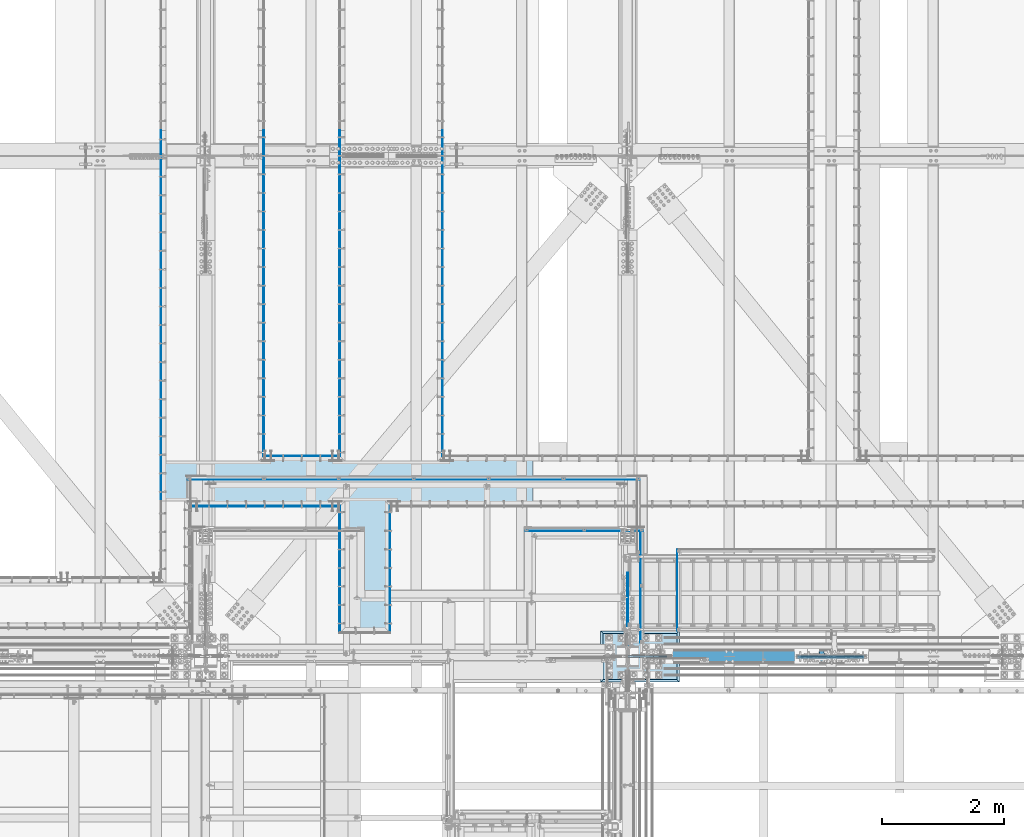
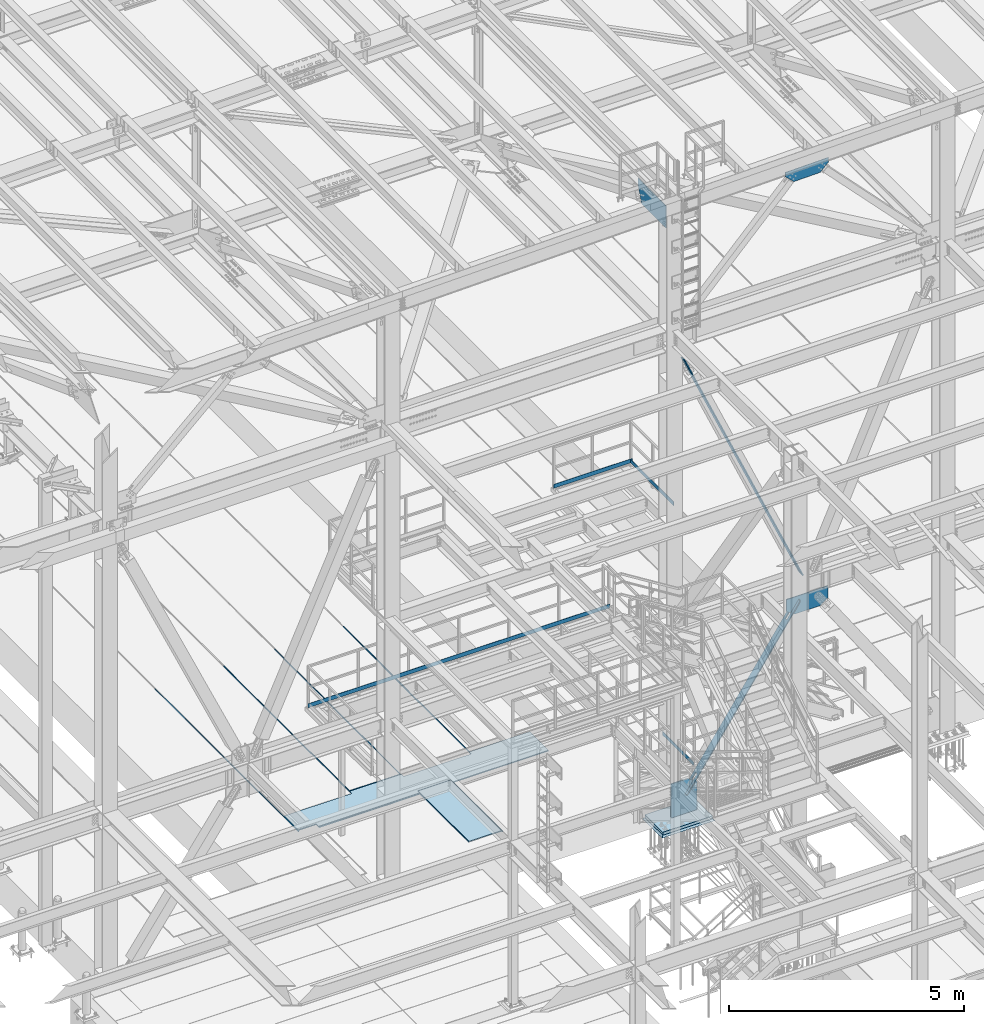
# One storey, part 2973 of 3843: 22 plates, 20 elements without a shape of their own.
"""IFC2X3 building model written with IfcOpenShell, lengths in millimetres."""

from ifc_helpers import new_model, si_unit, frame, origin_with_axes, place, context, subcontext, project, spatial, faceted_brep, material, type_object, element, aggregate, save


model = new_model("IFC2X3")

# Units and contexts
model_context = context("Model", 3, precision=1e-05, world=origin_with_axes())
body_context = subcontext(model_context, "Body", "Model", "MODEL_VIEW")
ifc_project = project(units=[si_unit("LENGTHUNIT", "METRE", prefix="MILLI"), si_unit("AREAUNIT", "SQUARE_METRE"), si_unit("VOLUMEUNIT", "CUBIC_METRE"), si_unit("MASSUNIT", "GRAM", prefix="KILO"), si_unit("TIMEUNIT", "SECOND"), si_unit("PLANEANGLEUNIT", "RADIAN"), si_unit("SOLIDANGLEUNIT", "STERADIAN"), si_unit("THERMODYNAMICTEMPERATUREUNIT", "DEGREE_CELSIUS"), si_unit("LUMINOUSINTENSITYUNIT", "LUMEN")], contexts=[model_context])

# Site, building, storey
site_placement = place(None, origin_with_axes())
site = spatial("IfcSite", under=ifc_project, at=site_placement, CompositionType="ELEMENT")
building_placement = place(site_placement, origin_with_axes())
building = spatial("IfcBuilding", under=site, at=building_placement, Name="Undefined", CompositionType="ELEMENT")
storey_placement = place(building_placement, origin_with_axes())
storey = spatial("IfcBuildingStorey", under=building, at=storey_placement, Name="Undefined", CompositionType="ELEMENT", Elevation=0.0)

# Assembly, plate
assembly_1_placement = place(storey_placement, origin_with_axes())
assembly_1 = element("IfcElementAssembly", 1, at=assembly_1_placement, inside=storey, Name="EMBED_ANGLE", AssemblyPlace="NOTDEFINED", PredefinedType="RIGID_FRAME")
ifc_material_1 = material(Name="STEEL/A36")
plate_type_1 = type_object("IfcPlateType", PredefinedType="NOTDEFINED")
plate_1_placement = place(assembly_1_placement, frame((52026.3120145524, 26000.0749962609, 30480.0000003815), z_axis=(0.0, 1.0, 0.0), x_axis=(0.0, 0.0, -1.0)))
plate_1 = element("IfcPlate", 2, at=plate_1_placement, type_object=plate_type_1, material=ifc_material_1, Name="PLATE", context=body_context, shape_type="Brep", body=[
    faceted_brep([(4.3054751586169e-07, -6.3500000025233, 2079.62499928574), (20.6374996185295, -6.3500000025233, 2079.62499928574), (25.3999996185303, -1.58750000270084, 2084.38754233986), (25.3999996702369, 6.34999999746651, 2092.32499955823), (4.33177774539217e-07, 6.34999999746651, 2092.32499955652), (25.3999996185303, 6.34999999999854, 12.6999999977998), (0.0, 6.34999999999854, 12.6999998092651), (0.0, -6.3499999046162, 0.0), (20.6375000381231, -6.35000000004948, 2.5465851649642e-11), (25.3999996185303, -1.58750000000146, 4.76249999779975)], [[[0, 1, 2, 3, 4]], [[4, 3, 5, 6]], [[0, 4, 6, 7]], [[1, 0, 7, 8]], [[2, 1, 8, 9]], [[3, 2, 9, 5]], [[8, 7, 6, 5, 9]]]),
])
aggregate(assembly_1, [plate_1])

assembly_2_placement = place(storey_placement, origin_with_axes())
assembly_2 = element("IfcElementAssembly", 3, at=assembly_2_placement, inside=storey, Name="EMBED_ANGLE", AssemblyPlace="NOTDEFINED", PredefinedType="RIGID_FRAME")
plate_2_placement = place(assembly_2_placement, frame((51200.8119901352, 26000.0749941487, 30480.0000003815), z_axis=(0.0, 1.0, 0.0), x_axis=(0.0, 0.0, -1.0)))
plate_2 = element("IfcPlate", 4, at=plate_2_placement, type_object=plate_type_1, material=ifc_material_1, Name="PLATE", context=body_context, shape_type="Brep", body=[
    faceted_brep([(20.6374996185295, 6.34999999747379, 2079.6250003181), (3.79157427232713e-07, 6.34999999747379, 2079.6250003181), (3.81471181754023e-07, -6.35000000253785, 2092.32499955647), (25.3999996185303, -6.35000000253785, 2092.32499955819), (25.3999996185303, 1.5874999971129, 2084.38750129905), (25.3999996185303, -6.34999999999854, 12.7000000000044), (25.399999618523, 1.58750000001601, 4.76249999998981), (20.6374996185295, 6.35000000000218, -7.27595761418343e-12), (7.27595761418343e-12, 6.3499999046162, 0.0), (0.0, -6.34999999999854, 12.6999998092651)], [[[0, 1, 2, 3, 4]], [[4, 3, 5, 6]], [[0, 4, 6, 7]], [[1, 0, 7, 8]], [[2, 1, 8, 9]], [[3, 2, 9, 5]], [[8, 7, 6, 5, 9]]]),
])
aggregate(assembly_2, [plate_2])

assembly_3_placement = place(storey_placement, origin_with_axes())
assembly_3 = element("IfcElementAssembly", 5, at=assembly_3_placement, inside=storey, Name="EMBED_ANGLE", AssemblyPlace="NOTDEFINED", PredefinedType="RIGID_FRAME")
plate_3_placement = place(assembly_3_placement, frame((49943.5120576172, 28911.5500000012, 30480.0000003815), z_axis=(1.0, 0.0, 0.0), x_axis=(0.0, 0.0, -1.0)))
plate_3 = element("IfcPlate", 6, at=plate_3_placement, type_object=plate_type_1, material=ifc_material_1, Name="PLATE", context=body_context, shape_type="Brep", body=[
    faceted_brep([(0.0, -6.3499999046162, 0.0), (0.0, 6.34999999999854, 12.6999998092651), (20.6374995967417, 6.34999999999854, 12.7000028258044), (25.3999996183447, 1.58750383952429, 7.93750642365194), (25.3999996185303, -6.34999999999491, 2.91038304567337e-11), (25.3999996185303, -6.34999999999854, 1263.64992675956), (3.81471181754023e-07, -6.34999999999854, 1263.64992675784), (3.77636752091348e-07, 6.34999999999854, 1250.94992675634), (20.6374996185295, 6.34999999999854, 1250.94992675634), (25.3999996185303, 1.58749999999782, 1255.71242675633)], [[[0, 1, 2, 3, 4]], [[0, 4, 5, 6]], [[1, 0, 6, 7]], [[2, 1, 7, 8]], [[3, 2, 8, 9]], [[4, 3, 9, 5]], [[8, 7, 6, 5, 9]]]),
])
aggregate(assembly_3, [plate_3])

assembly_4_placement = place(storey_placement, origin_with_axes())
assembly_4 = element("IfcElementAssembly", 7, at=assembly_4_placement, inside=storey, Name="EMBED_ANGLE", AssemblyPlace="NOTDEFINED", PredefinedType="RIGID_FRAME")
plate_4_placement = place(assembly_4_placement, frame((48724.3119799914, 28086.0499979783, 30480.0000003815), z_axis=(1.0, 0.0, 0.0), x_axis=(0.0, 0.0, -1.0)))
plate_4 = element("IfcPlate", 8, at=plate_4_placement, type_object=plate_type_1, material=ifc_material_1, Name="PLATE", context=body_context, shape_type="Brep", body=[
    faceted_brep([(0.0, -6.34999999999854, 12.6999998092651), (7.27595761418343e-12, 6.3499999046162, 0.0), (25.3999999999942, 6.34999999994034, 2.91038304567337e-11), (25.3999996185303, -1.58750000000873, 7.93749999998545), (20.6374996185259, -6.34999999993306, 12.7000361935643), (25.3999996185303, 6.34999999779393, 2482.84986160558), (25.3999996185303, -1.58749301118951, 2474.91236751944), (20.6374996185295, -6.35000000219225, 2470.14986234579), (3.79521225113422e-07, -6.35000000219225, 2470.14986234578), (3.81471181754023e-07, 6.34999999779393, 2482.84986160387)], [[[0, 1, 2, 3, 4]], [[3, 2, 5, 6]], [[4, 3, 6, 7]], [[0, 4, 7, 8]], [[1, 0, 8, 9]], [[2, 1, 9, 5]], [[8, 7, 6, 5, 9]]]),
])
aggregate(assembly_4, [plate_4])

assembly_5_placement = place(storey_placement, origin_with_axes())
assembly_5 = element("IfcElementAssembly", 9, at=assembly_5_placement, inside=storey, Name="EMBED_ANGLE", AssemblyPlace="NOTDEFINED", PredefinedType="RIGID_FRAME")
plate_5_placement = place(assembly_5_placement, frame((52889.8485419922, 34264.599609375, 30479.9999992371), z_axis=(0.0, -1.0, 0.0), x_axis=(0.0, 0.0, -1.0)))
plate_5 = element("IfcPlate", 10, at=plate_5_placement, type_object=plate_type_1, material=ifc_material_1, Name="PLATE", context=body_context, shape_type="Brep", body=[
    faceted_brep([(25.3999996185303, -6.34999999999491, 2.91038304567337e-11), (0.0, -6.3499999046162, 0.0), (7.27595761418343e-12, 6.3499999046162, 0.0), (20.6374996185295, 6.35000000000218, -7.27595761418343e-12), (25.3999996185921, 1.58750000000146, 7.27595761418343e-11), (25.3999996185303, -6.34999999999854, 5359.39950487583), (3.81471181754023e-07, -6.34999999999854, 5359.39950487583), (3.80572600988671e-07, 6.34999999999854, 5346.76203276939), (20.6374984696922, 6.34999999999854, 5346.76203276939), (25.3999991810269, 1.58750000000146, 5351.52458837546)], [[[0, 1, 2, 3, 4]], [[1, 0, 5, 6]], [[2, 1, 6, 7]], [[3, 2, 7, 8]], [[4, 3, 8, 9]], [[0, 4, 9, 5]], [[8, 7, 6, 5, 9]]]),
])
aggregate(assembly_5, [plate_5])

assembly_6_placement = place(storey_placement, origin_with_axes())
assembly_6 = element("IfcElementAssembly", 11, at=assembly_6_placement, inside=storey, Name="EMBED_ANGLE", AssemblyPlace="NOTDEFINED", PredefinedType="RIGID_FRAME")
plate_6_placement = place(assembly_6_placement, frame((51200.811984375, 34264.599609375, 30479.9999992371), z_axis=(0.0, -1.0, 0.0), x_axis=(0.0, 0.0, -1.0)))
plate_6 = element("IfcPlate", 12, at=plate_6_placement, type_object=plate_type_1, material=ifc_material_1, Name="PLATE", context=body_context, shape_type="Brep", body=[
    faceted_brep([(0.0, -6.3499999046162, 0.0), (7.27595761418343e-12, 6.3499999046162, 0.0), (25.3999999999942, 6.34999999994034, 2.91038304567337e-11), (25.3999996185921, -1.5874999999869, 7.27595761418343e-11), (20.6375000381231, -6.35000000004948, 2.5465851649642e-11), (25.3999984741276, 6.34999999999854, 5359.39960936416), (25.3999989004515, -1.58750000000146, 5351.46210937498), (20.6374984696922, -6.34999999999854, 5346.69960937498), (-7.611233741045e-07, -6.34999999999854, 5346.69960937498), (-7.62931449571624e-07, 6.34999999999854, 5359.39960936416)], [[[0, 1, 2, 3, 4]], [[3, 2, 5, 6]], [[4, 3, 6, 7]], [[0, 4, 7, 8]], [[1, 0, 8, 9]], [[2, 1, 9, 5]], [[8, 7, 6, 5, 9]]]),
])
aggregate(assembly_6, [plate_6])

assembly_7_placement = place(storey_placement, origin_with_axes())
assembly_7 = element("IfcElementAssembly", 13, at=assembly_7_placement, inside=storey, Name="EMBED_ANGLE", AssemblyPlace="NOTDEFINED", PredefinedType="RIGID_FRAME")
plate_7_placement = place(assembly_7_placement, frame((49949.8620576172, 34264.599609375, 30479.9999992371), z_axis=(0.0, -1.0, 0.0), x_axis=(0.0, 0.0, -1.0)))
plate_7 = element("IfcPlate", 14, at=plate_7_placement, type_object=plate_type_1, material=ifc_material_1, Name="PLATE", context=body_context, shape_type="Brep", body=[
    faceted_brep([(25.3999996185303, -6.34999999999491, 2.91038304567337e-11), (0.0, -6.3499999046162, 0.0), (7.27595761418343e-12, 6.3499999046162, 0.0), (20.6374996185295, 6.35000000000218, -7.27595761418343e-12), (25.3999996185921, 1.58750000000146, 7.27595761418343e-11), (25.3999996185303, -6.34999999999854, 5359.39960937378), (3.81471181754023e-07, -6.34999999999854, 5359.39960937378), (3.80568963009864e-07, 6.34999999999854, 5346.699609375), (20.6374984696922, 6.34999999999854, 5346.699609375), (25.3999987340248, 1.58750000000146, 5351.462109375)], [[[0, 1, 2, 3, 4]], [[1, 0, 5, 6]], [[2, 1, 6, 7]], [[3, 2, 7, 8]], [[4, 3, 8, 9]], [[0, 4, 9, 5]], [[8, 7, 6, 5, 9]]]),
])
aggregate(assembly_7, [plate_7])

assembly_8_placement = place(storey_placement, origin_with_axes())
assembly_8 = element("IfcElementAssembly", 15, at=assembly_8_placement, inside=storey, Name="EMBED_ANGLE", AssemblyPlace="NOTDEFINED", PredefinedType="RIGID_FRAME")
plate_8_placement = place(assembly_8_placement, frame((48260.7616210937, 34264.6001953124, 30479.999999237), z_axis=(0.0, -1.0, 0.0), x_axis=(0.0, 0.0, -1.0)))
plate_8 = element("IfcPlate", 16, at=plate_8_placement, type_object=plate_type_1, material=ifc_material_1, Name="PLATE", context=body_context, shape_type="Brep", body=[
    faceted_brep([(25.3999984709735, -1.58739354986028, 6096.0), (20.6375003814719, -6.34999999999854, 6096.00000000139), (20.6375000381231, -6.35000000004948, 2.5465851649642e-11), (25.3999996185303, -1.58733318374289, 0.0), (0.0, -6.3499999046162, 0.0), (3.81471181754023e-07, -6.34999999999854, 6096.0), (3.81471181754023e-07, 6.34999999999854, 6096.0), (7.27595761418343e-12, 6.3499999046162, 0.0), (25.3999996185303, 6.34999999999854, 6096.00000000171), (25.3999999999942, 6.34999999994034, 2.91038304567337e-11)], [[[0, 1, 2, 3]], [[4, 5, 6, 7]], [[8, 9, 7, 6]], [[9, 8, 0, 3]], [[4, 7, 9, 3, 2]], [[5, 4, 2, 1]], [[8, 6, 5, 1, 0]]]),
])
aggregate(assembly_8, [plate_8])

assembly_9_placement = place(storey_placement, origin_with_axes())
assembly_9 = element("IfcElementAssembly", 17, at=assembly_9_placement, inside=storey, Name="PLATE", AssemblyPlace="NOTDEFINED", PredefinedType="RIGID_FRAME")
ifc_material_2 = material(Name="STEEL/A572-50")
plate_type_2 = type_object("IfcPlateType", PredefinedType="NOTDEFINED")
plate_9_placement = place(assembly_9_placement, frame((51213.5118397988, 28181.2999946532, 30467.3), z_axis=(1.0, 0.0, 0.0), x_axis=(0.0, -1.0, 0.0)))
plate_9 = element("IfcPlate", 18, at=plate_9_placement, type_object=plate_type_2, material=ifc_material_2, Name="PLATE", context=body_context, shape_type="Brep", body=[
    faceted_brep([(0.0, -12.6999999999971, 0.0), (5.08003176946659e-05, -12.7000000000007, 800.100116695074), (5.08003176946659e-05, 12.7000000000007, 800.100116695074), (0.0, 12.6999999999971, 0.0), (2162.26889035886, -12.7000000000007, 800.099943196918), (2162.26889035886, 12.7000000000007, 800.099943196918), (2162.17500086908, -12.7000000000007, -6.18456397205591e-09), (2162.17500086908, 12.7000000000007, -6.18456397205591e-09)], [[[0, 1, 2, 3]], [[1, 4, 5, 2]], [[4, 6, 7, 5]], [[6, 0, 3, 7]], [[5, 7, 3, 2]], [[6, 4, 1, 0]]]),
])
aggregate(assembly_9, [plate_9])

assembly_10_placement = place(storey_placement, origin_with_axes())
assembly_10 = element("IfcElementAssembly", 19, at=assembly_10_placement, inside=storey, Name="PLATE", AssemblyPlace="NOTDEFINED", PredefinedType="RIGID_FRAME")
plate_10_placement = place(assembly_10_placement, frame((54369.4599275701, 28098.7501351559, 30467.3), z_axis=(-0.999999912959143, -0.000417230999984894, 0.0), x_axis=(-0.000417230999984844, 0.999999912959143, 0.0)))
plate_10 = element("IfcPlate", 20, at=plate_10_placement, type_object=plate_type_2, material=ifc_material_2, Name="PLATE", context=body_context, shape_type="Brep", body=[
    faceted_brep([(800.710245577098, -12.7000000000007, 1491.91402874105), (800.711679697099, 12.7000000000007, 1491.91402814275), (705.344684826359, 12.7000000000007, 1491.95381401691), (705.344684826359, -12.7000000000007, 1491.95381401691), (706.038755781825, 12.7000000000007, 3155.65366924289), (706.038755781825, -12.7000000000007, 3155.65366924289), (801.396752079436, -12.7000000000007, 3155.61388712282), (801.399785450591, 12.7000000000007, 3155.61388585734), (800.094624510304, -12.7000000000007, 8.22183210402727e-10), (0.0, -12.6999999999971, 0.0), (0.0, 12.6999999999971, 0.0), (800.094624510304, 12.7000000000007, 8.22183210402727e-10), (0.980195927109889, -12.7000000000007, 2349.49786124886), (0.980195927109889, 12.7000000000007, 2349.49786124886), (89.8800330390695, -12.7000000000007, 2349.46079358684), (89.8800330390695, 12.7000000000007, 2349.46079358684), (90.2191208858239, -12.7000000000007, 3162.26072285765), (90.2191208858239, 12.7000000000007, 3162.26072285765), (1.31929102188224, -12.7000000000007, 3162.29781062532), (1.31929102188224, 12.7000000000007, 3162.29781062532), (2.3564450729973, -12.7000000000007, 5648.32244865219), (2.3564450729973, 12.7000000000007, 5648.32244865219), (107.131251092302, -12.7000000000007, 5648.27872465517), (107.131251092302, 12.7000000000007, 5648.27872465517), (107.318008417285, -12.7000000000007, 6095.95573936908), (107.318008426177, 12.7000000000007, 6095.95576068611), (707.392937012552, -12.7000000000007, 6095.70542471548), (707.392937013767, 12.7000000000007, 6095.7054276349), (706.698891767679, -12.7000000000007, 4432.00343146316), (706.698891767679, 12.7000000000007, 4432.00343146316), (801.923423068169, -12.7000000000007, 4431.96370521604), (801.927683345679, 12.7000000000007, 4431.96370345399)], [[[0, 1, 2, 3]], [[3, 2, 4, 5]], [[6, 5, 4, 7]], [[8, 9, 10, 11]], [[10, 9, 12, 13]], [[14, 15, 13, 12]], [[16, 17, 15, 14]], [[18, 19, 17, 16]], [[19, 18, 20, 21]], [[22, 23, 21, 20]], [[24, 25, 23, 22]], [[25, 24, 26, 27]], [[26, 28, 29, 27]], [[30, 31, 29, 28]], [[31, 30, 6, 7]], [[2, 1, 11, 10, 13, 15, 17, 19, 21, 23, 25, 27, 29, 31, 7, 4]], [[8, 11, 1, 0]], [[30, 28, 26, 24, 22, 20, 18, 16, 14, 12, 9, 8, 0, 3, 5, 6]]]),
])
aggregate(assembly_10, [plate_10])

# Assembly, plates
assembly_11_placement = place(storey_placement, origin_with_axes())
assembly_11 = element("IfcElementAssembly", 21, at=assembly_11_placement, inside=storey, Name="RAIL", AssemblyPlace="NOTDEFINED", PredefinedType="RIGID_FRAME")
plate_type_3 = type_object("IfcPlateType", PredefinedType="NOTDEFINED")
plate_11_placement = place(assembly_11_placement, frame((56143.525012207, 27676.4747862042, 37579.2999983618), z_axis=(0.0, 0.0, 1.0), x_axis=(0.0, -1.0, 0.0)))
plate_11 = element("IfcPlate", 22, at=plate_11_placement, type_object=plate_type_3, material=ifc_material_1, Name="TOE_PLATE", context=body_context, shape_type="Brep", body=[
    faceted_brep([(0.0, -3.17499999999927, 0.0), (0.0, -3.17499999999927, 101.600000000006), (0.0, 3.17499999999927, 101.600000000006), (0.0, 3.17499999999927, 0.0), (1838.32478849919, -3.17500000000291, 101.599999999999), (1838.32478849919, 3.17500000000291, 101.599999999999), (1838.32478849919, -3.17500000000291, 0.0), (1838.32478849919, 3.17500000000291, 0.0)], [[[0, 1, 2, 3]], [[1, 4, 5, 2]], [[4, 6, 7, 5]], [[6, 0, 3, 7]], [[5, 7, 3, 2]], [[6, 4, 1, 0]]]),
])
plate_12_placement = place(assembly_11_placement, frame((54254.4, 27679.6497862042, 37579.2999983618), z_axis=(0.0, 0.0, 1.0), x_axis=(1.0, 0.0, 0.0)))
plate_12 = element("IfcPlate", 23, at=plate_12_placement, type_object=plate_type_3, material=ifc_material_1, Name="TOE_PLATE", context=body_context, shape_type="Brep", body=[
    faceted_brep([(0.0, -3.17499999999927, 0.0), (0.0, -3.17499999999927, 101.600000000006), (0.0, 3.17499999999927, 101.600000000006), (0.0, 3.17499999999927, 0.0), (1930.40001220701, -3.17499999999927, 101.599999999999), (1930.40001220701, 3.17499999999927, 101.599999999999), (1930.40001220701, -3.17499999999927, 0.0), (1930.40001220701, 3.17499999999927, 0.0)], [[[0, 1, 2, 3]], [[1, 4, 5, 2]], [[4, 6, 7, 5]], [[6, 0, 3, 7]], [[5, 7, 3, 2]], [[6, 4, 1, 0]]]),
])
aggregate(assembly_11, [plate_11, plate_12])

# Assembly, plate
assembly_12_placement = place(storey_placement, origin_with_axes())
assembly_12 = element("IfcElementAssembly", 24, at=assembly_12_placement, inside=storey, Name="RAIL", AssemblyPlace="NOTDEFINED", PredefinedType="RIGID_FRAME")
plate_13_placement = place(assembly_12_placement, frame((48704.499999976, 28521.025, 33312.1000002631), z_axis=(0.0, 0.0, 1.0), x_axis=(1.0, 0.0, 0.0)))
plate_13 = element("IfcPlate", 25, at=plate_13_placement, type_object=plate_type_3, material=ifc_material_2, Name="TOE_PLATE", context=body_context, shape_type="Brep", body=[
    faceted_brep([(0.0, -3.17499999999927, 0.0), (0.0, -3.17499999999927, 101.600000000006), (0.0, 3.17499999999927, 101.600000000006), (0.0, 3.17499999999927, 0.0), (7423.14999996749, -3.17499999999927, 101.599999999999), (7423.14999996749, 3.17499999999927, 101.599999999999), (7423.14999996749, -3.17499999999927, 0.0), (7423.14999996749, 3.17499999999927, 0.0)], [[[0, 1, 2, 3]], [[1, 4, 5, 2]], [[4, 6, 7, 5]], [[6, 0, 3, 7]], [[5, 7, 3, 2]], [[6, 4, 1, 0]]]),
])
aggregate(assembly_12, [plate_13])

assembly_13_placement = place(storey_placement, origin_with_axes())
assembly_13 = element("IfcElementAssembly", 26, at=assembly_13_placement, inside=storey, Name="RAIL", AssemblyPlace="NOTDEFINED", PredefinedType="RIGID_FRAME")
plate_14_placement = place(assembly_13_placement, frame((56746.7750000085, 27368.50000005, 30492.6999999739), z_axis=(0.0, 0.0, 1.0), x_axis=(0.0, -1.0, 0.0)))
plate_14 = element("IfcPlate", 27, at=plate_14_placement, type_object=plate_type_3, material=ifc_material_1, Name="TOE_PLATE", context=body_context, shape_type="Brep", body=[
    faceted_brep([(0.0, -3.17499999999927, 0.0), (0.0, -3.17499999999927, 101.600000000006), (0.0, 3.17499999999927, 101.600000000006), (0.0, 3.17499999999927, 0.0), (1327.14999999064, -3.17500000000291, 101.599999999999), (1327.14999999064, 3.17500000000291, 101.599999999999), (1327.14999999064, -3.17500000000291, 0.0), (1327.14999999064, 3.17500000000291, 0.0)], [[[0, 1, 2, 3]], [[1, 4, 5, 2]], [[4, 6, 7, 5]], [[6, 0, 3, 7]], [[5, 7, 3, 2]], [[6, 4, 1, 0]]]),
])
aggregate(assembly_13, [plate_14])

assembly_14_placement = place(storey_placement, origin_with_axes())
assembly_14 = element("IfcElementAssembly", 28, at=assembly_14_placement, inside=storey, Name="CB", AssemblyPlace="NOTDEFINED", PredefinedType="RIGID_FRAME")
plate_type_4 = type_object("IfcPlateType", PredefinedType="NOTDEFINED")
plate_15_placement = place(assembly_14_placement, frame((56274.1689244087, 25519.0625, 30182.1532434462), z_axis=(0.564372610296811, 0.0, 0.825520173434159), x_axis=(0.0, 1.0, 0.0)))
plate_15 = element("IfcPlate", 29, at=plate_15_placement, type_object=plate_type_4, material=ifc_material_1, Name="CB", context=body_context, shape_type="Brep", body=[
    faceted_brep([(0.0, -12.7000000001135, 65.0875015259007), (0.0, -12.699999990713, 4902.99609687838), (0.0, 12.7000000092085, 4902.99609687839), (0.0, 12.6999999999025, 65.0875015259462), (4.95449104382351, -12.6999999906693, 4927.90400536637), (4.95449104382351, 12.7000000092521, 4927.90400536637), (19.0636878264413, -12.6999999906257, 4949.01991057782), (19.0636878264413, 12.7000000092958, 4949.01991057782), (40.1795930378867, -12.6999999905966, 4963.12910736044), (40.1795930378867, 12.7000000093249, 4963.12910736044), (65.0875000000015, -12.6999999905966, 4968.08359840425), (65.0875000000015, 12.7000000093394, 4968.08359840426), (65.0875000000015, -12.6999999915861, 4436.66679921074), (65.0875000000015, 12.7000000083353, 4436.66679921074), (128.587500000001, -12.6999999915861, 4436.66679921074), (128.587500000001, 12.7000000083353, 4436.66679921074), (128.587498474124, -12.6999999905966, 4968.08359840425), (128.587498474124, 12.7000000093394, 4968.08359840426), (153.495406962116, -12.6999999905966, 4963.12910736044), (153.495406962116, 12.7000000093249, 4963.12910736044), (174.611312173562, -12.6999999906257, 4949.01991057782), (174.611312173562, 12.7000000092958, 4949.01991057782), (188.720508956179, -12.6999999906693, 4927.90400536637), (188.720508956179, 12.7000000092521, 4927.90400536637), (193.675000000003, -12.699999990713, 4902.99609687838), (193.675000000003, 12.7000000092085, 4902.99609687839), (193.674999999988, -12.7000000001135, 65.0875015259007), (193.674999999988, 12.6999999999025, 65.0875015259462), (188.720508956161, -12.7000000000698, 40.1795930378939), (188.720508956161, 12.6999999999389, 40.1795930379376), (174.611312173554, -12.7000000000407, 19.0636878264304), (174.611312173554, 12.6999999999753, 19.0636878264741), (153.495406962102, -12.7000000000189, 4.9544910438035), (153.495406962102, 12.7000000000044, 4.95449104384716), (128.587499999994, -12.7000000000044, -2.00088834390044e-11), (128.587499999994, 12.7000000000116, 1.81898940354586e-11), (128.587499999994, -12.6999999980762, 531.416799185412), (128.587499999994, 12.7000000018015, 531.416799185514), (65.0874999999942, -12.6999999980762, 531.416799185412), (65.0874999999942, 12.7000000018015, 531.416799185514), (65.0875015258789, -12.7000000000044, -2.00088834390044e-11), (65.0875015258789, 12.7000000000116, 1.81898940354586e-11), (40.1795930378867, -12.7000000000189, 4.9544910438035), (40.1795930378867, 12.7000000000044, 4.95449104384716), (19.063687826434, -12.7000000000407, 19.0636878264304), (19.063687826434, 12.6999999999753, 19.0636878264741), (4.95449104382715, -12.7000000000698, 40.1795930378939), (4.95449104382715, 12.6999999999389, 40.1795930379376)], [[[0, 1, 2, 3]], [[1, 4, 5, 2]], [[4, 6, 7, 5]], [[6, 8, 9, 7]], [[8, 10, 11, 9]], [[10, 12, 13, 11]], [[12, 14, 15, 13]], [[14, 16, 17, 15]], [[16, 18, 19, 17]], [[18, 20, 21, 19]], [[20, 22, 23, 21]], [[22, 24, 25, 23]], [[24, 26, 27, 25]], [[26, 28, 29, 27]], [[28, 30, 31, 29]], [[30, 32, 33, 31]], [[32, 34, 35, 33]], [[34, 36, 37, 35]], [[36, 38, 39, 37]], [[38, 40, 41, 39]], [[40, 42, 43, 41]], [[42, 44, 45, 43]], [[44, 46, 47, 45]], [[46, 0, 3, 47]], [[5, 7, 9, 11, 13, 15, 17, 19, 21, 23, 25, 27, 29, 31, 33, 35, 37, 39, 41, 43, 45, 47, 3, 2]], [[46, 44, 42, 40, 38, 36, 34, 32, 30, 28, 26, 24, 22, 20, 18, 16, 14, 12, 10, 8, 6, 4, 1, 0]]]),
])
aggregate(assembly_14, [plate_15])

assembly_15_placement = place(storey_placement, origin_with_axes())
assembly_15 = element("IfcElementAssembly", 30, at=assembly_15_placement, inside=storey, Name="CB", AssemblyPlace="NOTDEFINED", PredefinedType="RIGID_FRAME")
plate_16_placement = place(assembly_15_placement, frame((59154.3756779111, 25712.7375, 34880.5775836357), z_axis=(-0.402959140980662, 0.0, 0.915217968956099), x_axis=(0.0, -1.0, 0.0)))
plate_16 = element("IfcPlate", 31, at=plate_16_placement, type_object=plate_type_4, material=ifc_material_1, Name="CB", context=body_context, shape_type="Brep", body=[
    faceted_brep([(0.0, -12.7000000001135, 65.0875015259007), (0.0, -12.6999999967738, 7188.99609679334), (0.0, 12.7000000032567, 7188.99609679332), (0.0, 12.6999999999025, 65.0875015259462), (4.95449104382351, -12.6999999967666, 7213.90400528136), (4.95449104382351, 12.7000000032713, 7213.90400528136), (19.0636878264413, -12.699999996752, 7235.01991049284), (19.0636878264413, 12.7000000032858, 7235.01991049282), (40.1795930378867, -12.6999999967375, 7249.12910727547), (40.1795930378867, 12.7000000032858, 7249.12910727546), (65.0875000000015, -12.6999999967447, 7254.0835983193), (65.0875000000015, 12.7000000032931, 7254.08359831929), (65.0875000000015, -12.6999999969703, 6767.11679913235), (65.0875000000015, 12.7000000030675, 6767.11679913234), (128.587500000001, -12.6999999969703, 6767.11679913235), (128.587500000001, 12.7000000030675, 6767.11679913234), (128.587498474124, -12.6999999967447, 7254.0835983193), (128.587498474124, 12.7000000032931, 7254.08359831929), (153.495406962116, -12.6999999967375, 7249.12910727547), (153.495406962116, 12.7000000032858, 7249.12910727546), (174.611312173562, -12.699999996752, 7235.01991049284), (174.611312173562, 12.7000000032858, 7235.01991049282), (188.720508956179, -12.6999999967666, 7213.90400528136), (188.720508956179, 12.7000000032713, 7213.90400528136), (193.675000000003, -12.6999999967738, 7188.99609679334), (193.675000000003, 12.7000000032567, 7188.99609679332), (193.674999999988, -12.7000000001135, 65.0875015259007), (193.674999999988, 12.6999999999025, 65.0875015259462), (188.720508956161, -12.7000000000698, 40.1795930378939), (188.720508956161, 12.6999999999389, 40.1795930379376), (174.611312173554, -12.7000000000407, 19.0636878264304), (174.611312173554, 12.6999999999753, 19.0636878264741), (153.495406962102, -12.7000000000189, 4.9544910438035), (153.495406962102, 12.7000000000044, 4.95449104384716), (128.587499999994, -12.7000000000044, -2.00088834390044e-11), (128.587499999994, 12.7000000000116, 1.81898940354586e-11), (128.587499999994, -12.7000000008265, 486.966799195696), (128.587499999994, 12.6999999991895, 486.966799195738), (65.0874999999942, -12.7000000008265, 486.966799195696), (65.0874999999942, 12.6999999991895, 486.966799195738), (65.0875015258789, -12.7000000000044, -2.00088834390044e-11), (65.0875015258789, 12.7000000000116, 1.81898940354586e-11), (40.1795930378867, -12.7000000000189, 4.9544910438035), (40.1795930378867, 12.7000000000044, 4.95449104384716), (19.063687826434, -12.7000000000407, 19.0636878264304), (19.063687826434, 12.6999999999753, 19.0636878264741), (4.95449104382715, -12.7000000000698, 40.1795930378939), (4.95449104382715, 12.6999999999389, 40.1795930379376)], [[[0, 1, 2, 3]], [[1, 4, 5, 2]], [[4, 6, 7, 5]], [[6, 8, 9, 7]], [[8, 10, 11, 9]], [[10, 12, 13, 11]], [[12, 14, 15, 13]], [[14, 16, 17, 15]], [[16, 18, 19, 17]], [[18, 20, 21, 19]], [[20, 22, 23, 21]], [[22, 24, 25, 23]], [[24, 26, 27, 25]], [[26, 28, 29, 27]], [[28, 30, 31, 29]], [[30, 32, 33, 31]], [[32, 34, 35, 33]], [[34, 36, 37, 35]], [[36, 38, 39, 37]], [[38, 40, 41, 39]], [[40, 42, 43, 41]], [[42, 44, 45, 43]], [[44, 46, 47, 45]], [[46, 0, 3, 47]], [[5, 7, 9, 11, 13, 15, 17, 19, 21, 23, 25, 27, 29, 31, 33, 35, 37, 39, 41, 43, 45, 47, 3, 2]], [[46, 44, 42, 40, 38, 36, 34, 32, 30, 28, 26, 24, 22, 20, 18, 16, 14, 12, 10, 8, 6, 4, 1, 0]]]),
])
aggregate(assembly_15, [plate_16])

assembly_16_placement = place(storey_placement, origin_with_axes())
assembly_16 = element("IfcElementAssembly", 32, at=assembly_16_placement, inside=storey, Name="BEAM", AssemblyPlace="NOTDEFINED", PredefinedType="RIGID_FRAME")
plate_type_5 = type_object("IfcPlateType", PredefinedType="NOTDEFINED")
plate_17_placement = place(assembly_16_placement, frame((58773.9543087284, 25615.9, 34055.2341196748), z_axis=(1.0, 0.0, 0.0), x_axis=(0.0, 0.0, 1.0)))
plate_17 = element("IfcPlate", 33, at=plate_17_placement, type_object=plate_type_5, material=ifc_material_2, Name="CB", context=body_context, shape_type="Brep", body=[
    faceted_brep([(0.0, -12.6999999999971, 0.0), (-137.974993902317, -12.7000000000007, 201.819044400312), (-137.974993902317, 12.7000000000007, 201.819044400312), (0.0, 12.6999999999971, 0.0), (-137.974993902317, -12.7000000000007, 516.789440510169), (-137.974993902317, 12.7000000000007, 516.789440510169), (-137.974993902317, -12.7000000000007, 817.424322857521), (-137.974993902317, 12.7000000000007, 817.424322857521), (0.627029945222603, -12.7000000000007, 1020.25655276446), (0.627029945222603, 12.7000000000007, 1020.25655276446), (304.615880325218, -12.7000000000007, 1020.25655276446), (304.615880325218, 12.7000000000007, 1020.25655276446), (304.615880325218, 12.7000000000007, 0.0), (304.615880325218, -12.7000000000007, 0.0)], [[[0, 1, 2, 3]], [[1, 4, 5, 2]], [[4, 6, 7, 5]], [[6, 8, 9, 7]], [[9, 8, 10, 11]], [[3, 2, 5, 7, 9, 11, 12]], [[0, 3, 12, 13]], [[8, 6, 4, 1, 0, 13, 10]], [[12, 11, 10, 13]]]),
])
aggregate(assembly_16, [plate_17])

assembly_17_placement = place(storey_placement, origin_with_axes())
assembly_17 = element("IfcElementAssembly", 34, at=assembly_17_placement, inside=storey, Name="COLUMN", AssemblyPlace="NOTDEFINED", PredefinedType="RIGID_FRAME")
plate_type_6 = type_object("IfcPlateType", PredefinedType="NOTDEFINED")
plate_18_placement = place(assembly_17_placement, frame((55937.94375, 25615.9, 29679.9), z_axis=(0.0, 0.0, 1.0), x_axis=(1.0, 0.0, 0.0)))
plate_18 = element("IfcPlate", 35, at=plate_18_placement, type_object=plate_type_6, material=ifc_material_2, Name="CB", context=body_context, shape_type="Brep", body=[
    faceted_brep([(0.0, -12.6999999999971, 19.0499992370605), (0.0, -12.7000000000007, 863.638095663388), (0.0, 12.7000000000007, 863.638095663388), (0.0, 12.6999999999971, 19.0499992370605), (19.0499992370605, -12.7000000000007, 882.688094900448), (19.0499992370605, 12.7000000000007, 882.688094900448), (417.57241523535, -12.7000000000007, 882.688094900452), (417.57241523535, 12.7000000000007, 882.688094900452), (640.290098696336, -12.7000000000007, 730.42560099814), (640.290098696336, 12.7000000000007, 730.42560099814), (640.290098696336, -12.7000000000007, 0.0), (640.290098696336, 12.7000000000007, 0.0), (19.0500015258731, -12.6999999999971, -6.33008312433958e-10), (19.0500015258731, 12.6999999999971, 0.0)], [[[0, 1, 2, 3]], [[1, 4, 5, 2]], [[4, 6, 7, 5]], [[6, 8, 9, 7]], [[8, 10, 11, 9]], [[10, 12, 13, 11]], [[12, 0, 3, 13]], [[5, 7, 9, 11, 13, 3, 2]], [[12, 10, 8, 6, 4, 1, 0]]]),
])

assembly_18_placement = place(storey_placement, origin_with_axes())
assembly_18 = element("IfcElementAssembly", 36, at=assembly_18_placement, inside=storey, Name="PLATE", AssemblyPlace="NOTDEFINED", PredefinedType="RIGID_FRAME")
plate_type_7 = type_object("IfcPlateType", PredefinedType="NOTDEFINED")
plate_19_placement = place(assembly_18_placement, frame((55930.8, 25800.0499999991, 45473.6160239086), z_axis=(0.0, 1.0, 0.0), x_axis=(0.0, 0.0, -1.0)))
plate_19 = element("IfcPlate", 37, at=plate_19_placement, type_object=plate_type_7, material=ifc_material_2, Name="PLATE", context=body_context, shape_type="Brep", body=[
    faceted_brep([(576.149068687271, -7.9375, 1021.10815247552), (576.149068687278, -7.9375, 0.0), (576.149068687278, 7.9375, 0.0), (576.149068687271, 7.9375, 1021.10815247552), (165.054947504475, -7.9375, 1190.16989719899), (165.054947504475, 7.9375, 1190.16989719899), (-7.27595761418343e-12, -7.9375, 1190.16989719899), (-7.27595761418343e-12, 7.9375, 1190.16989719899), (0.0, -7.9375, 0.0), (0.0, 7.9375, 0.0)], [[[0, 1, 2, 3]], [[4, 0, 3, 5]], [[6, 4, 5, 7]], [[1, 0, 4, 6, 8]], [[1, 8, 9, 2]], [[5, 3, 2, 9, 7]], [[8, 6, 7, 9]]]),
])
aggregate(assembly_18, [plate_19])

assembly_19_placement = place(storey_placement, origin_with_axes())
assembly_19 = element("IfcElementAssembly", 38, at=assembly_19_placement, inside=storey, Name="BEAM", AssemblyPlace="NOTDEFINED", PredefinedType="RIGID_FRAME")
plate_type_8 = type_object("IfcPlateType", PredefinedType="NOTDEFINED")
plate_20_placement = place(assembly_19_placement, frame((58741.5445922883, 25603.2000006061, 45471.2516948417), z_axis=(0.0212609600051656, 0.0, -0.999773960242843), x_axis=(0.999773960242844, 0.0, 0.0212609600051649)))
plate_20 = element("IfcPlate", 39, at=plate_20_placement, type_object=plate_type_8, material=ifc_material_2, context=body_context, shape_type="Brep", body=[
    faceted_brep([(0.0, -6.3499999046162, 0.0), (-0.0696391853125533, -6.34999999999854, 107.668120863986), (-0.0696391853125533, 6.34999999999854, 107.668120863986), (7.27595761418343e-12, 6.3499999046162, 0.0), (204.867924250575, -6.34999999999854, 312.75453975876), (204.867924250575, 6.34999999999854, 312.75453975876), (849.473396180387, -6.34999999999854, 312.824728924614), (849.473396180387, 6.34999999999854, 312.824728924614), (1063.65613877077, -6.34999999999854, 115.833960502532), (1063.65613877077, 6.34999999999854, 115.833960502532), (1063.7728381721, -6.34999999999854, 3.02679836750031e-09), (1063.7728381721, 6.34999999999854, 3.02679836750031e-09)], [[[0, 1, 2, 3]], [[1, 4, 5, 2]], [[4, 6, 7, 5]], [[6, 8, 9, 7]], [[8, 10, 11, 9]], [[10, 0, 3, 11]], [[5, 7, 9, 11, 3, 2]], [[10, 8, 6, 4, 1, 0]]]),
])
aggregate(assembly_19, [plate_20])

# Plate
plate_type_9 = type_object("IfcPlateType", PredefinedType="NOTDEFINED")
plate_21_placement = place(assembly_17_placement, frame((55524.4, 25996.9, 29641.8), z_axis=(1.0, 0.0, 0.0), x_axis=(0.0, -1.0, 0.0)))
plate_21 = element("IfcPlate", 40, at=plate_21_placement, type_object=plate_type_9, material=ifc_material_2, Name="PLATE", context=body_context, shape_type="Brep", body=[
    faceted_brep([(0.0, -38.0999999999985, 0.0), (0.0, -38.0999999999985, 1219.19995117188), (0.0, 38.0999999999985, 1219.19995117188), (0.0, 38.0999999999985, 0.0), (762.0, -38.0999999999985, 1219.19995117188), (762.0, 38.0999999999985, 1219.19995117188), (762.0, -38.0999999999985, 0.0), (762.0, 38.0999999999985, 0.0)], [[[0, 1, 2, 3]], [[1, 4, 5, 2]], [[4, 6, 7, 5]], [[6, 0, 3, 7]], [[5, 7, 3, 2]], [[6, 4, 1, 0]]]),
])

aggregate(assembly_17, [plate_18, plate_21])

# Assembly, plate
assembly_20_placement = place(storey_placement, origin_with_axes())
assembly_20 = element("IfcElementAssembly", 41, at=assembly_20_placement, inside=storey, Name="GROUT", AssemblyPlace="NOTDEFINED", PredefinedType="REINFORCEMENT_UNIT")
ifc_material_3 = material(Name="CONCRETE/Concrete_Undefined")
plate_type_10 = type_object("IfcPlateType", PredefinedType="NOTDEFINED")
plate_22_placement = place(assembly_20_placement, frame((55486.3, 26035.0, 29584.65), z_axis=(1.0, 0.0, 0.0), x_axis=(0.0, -1.0, 0.0)))
plate_22 = element("IfcPlate", 42, at=plate_22_placement, type_object=plate_type_10, material=ifc_material_3, Name="GROUT", context=body_context, shape_type="Brep", body=[
    faceted_brep([(38.1000000006898, -19.0499999997955, 1257.29999999931), (0.0, 19.0499999999993, 1295.40002441406), (0.0, 19.0500000000029, 0.0), (38.1000000006916, -19.0499999999811, 38.1000000006607), (800.099999999336, -19.0499999998101, 38.1000000006607), (838.200012207031, 19.0499999999993, 0.0), (838.200012207031, 19.0499999999993, 1295.40002441406), (800.099999999336, -19.0499999999956, 1257.29999999931)], [[[0, 1, 2, 3]], [[4, 5, 6, 7]], [[4, 7, 0, 3]], [[5, 4, 3, 2]], [[6, 5, 2, 1]], [[7, 6, 1, 0]]]),
])
aggregate(assembly_20, [plate_22])

save(model, "model.ifc")
